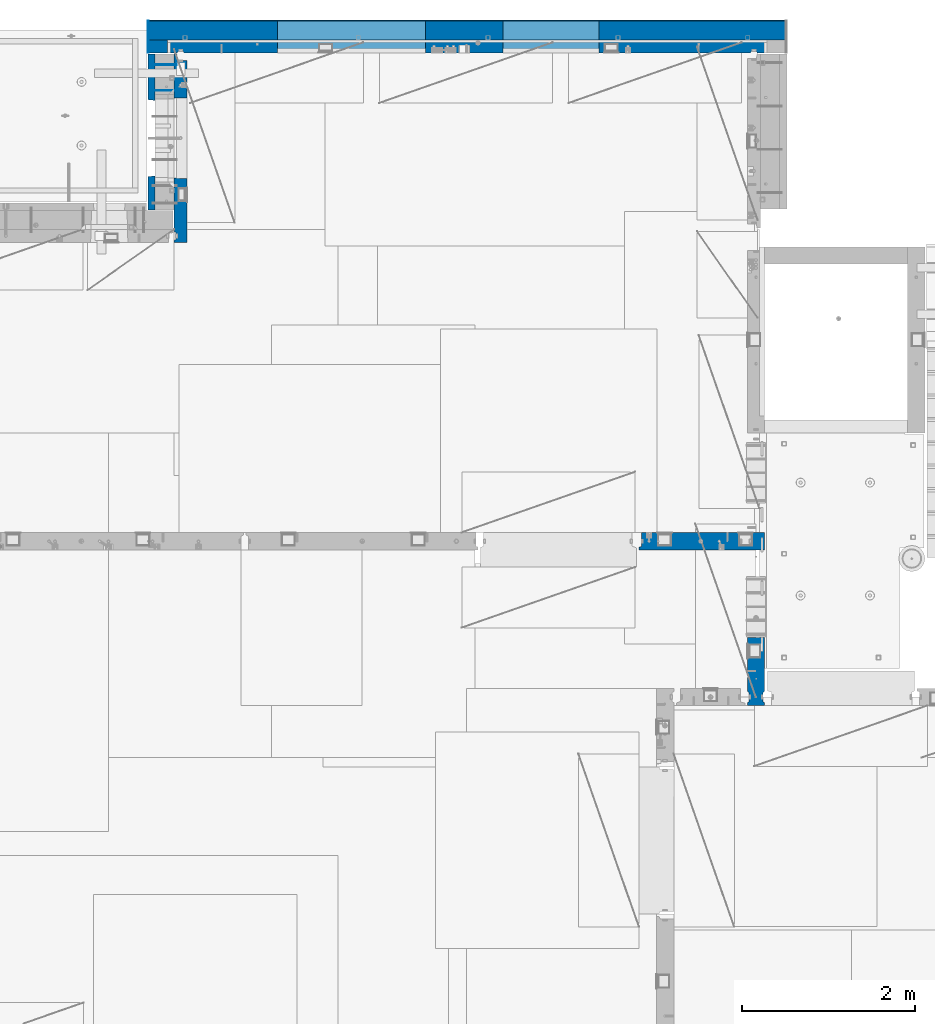
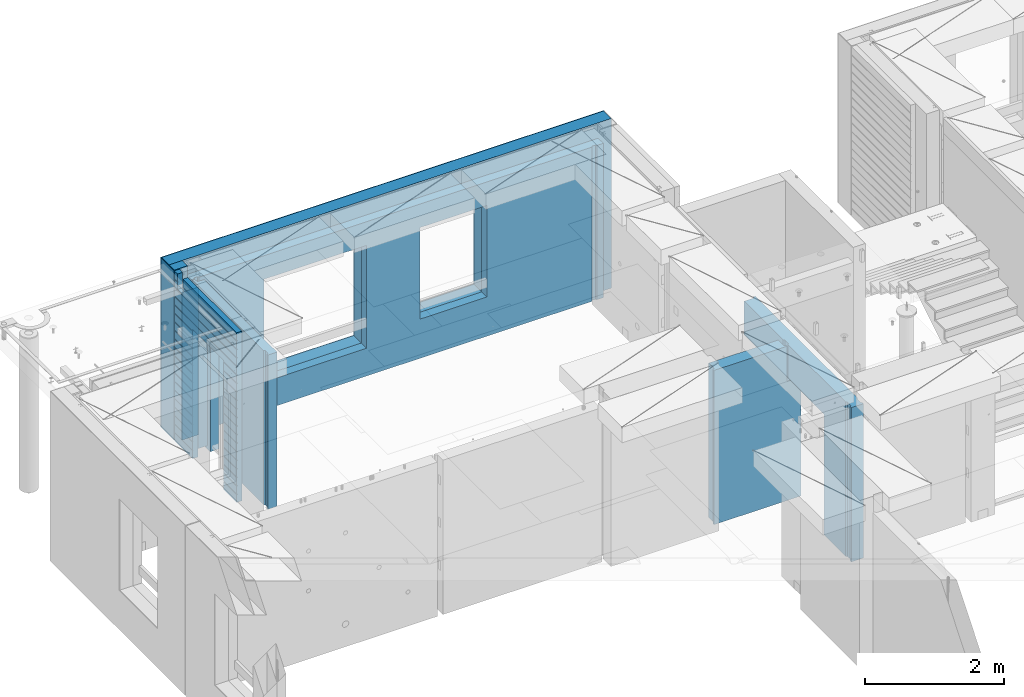
# One storey, part 226 of 334: 11 walls, 4 elements without a shape of their own.
"""IFC2X3 building model written with IfcOpenShell, lengths in millimetres."""

from ifc_helpers import new_model, si_unit, frame, origin_with_axes, place, context, subcontext, project, spatial, faceted_brep, material, type_object, element, aggregate, save


model = new_model("IFC2X3")

# Units and contexts
model_context = context("Model", 3, precision=1e-05, world=origin_with_axes())
body_context = subcontext(model_context, "Body", "Model", "MODEL_VIEW")
ifc_project = project(units=[si_unit("LENGTHUNIT", "METRE", prefix="MILLI"), si_unit("AREAUNIT", "SQUARE_METRE"), si_unit("VOLUMEUNIT", "CUBIC_METRE"), si_unit("MASSUNIT", "GRAM", prefix="KILO"), si_unit("TIMEUNIT", "SECOND"), si_unit("PLANEANGLEUNIT", "RADIAN"), si_unit("SOLIDANGLEUNIT", "STERADIAN"), si_unit("THERMODYNAMICTEMPERATUREUNIT", "DEGREE_CELSIUS"), si_unit("LUMINOUSINTENSITYUNIT", "LUMEN")], contexts=[model_context])

# Site, building, storey
site_placement = place(None, origin_with_axes())
site = spatial("IfcSite", under=ifc_project, at=site_placement, CompositionType="ELEMENT")
building_placement = place(site_placement, origin_with_axes())
building = spatial("IfcBuilding", under=site, at=building_placement, CompositionType="ELEMENT")
storey_placement = place(building_placement, origin_with_axes())
storey = spatial("IfcBuildingStorey", under=building, at=storey_placement, Name="3", CompositionType="ELEMENT", Elevation=0.0)

# Assembly, walls
assembly_1_placement = place(storey_placement, origin_with_axes())
assembly_1 = element("IfcElementAssembly", 1, at=assembly_1_placement, inside=storey, AssemblyPlace="NOTDEFINED", PredefinedType="REINFORCEMENT_UNIT")
ifc_material_1 = material(Name="Undefined")
wall_type_1 = type_object("IfcWallType", PredefinedType="NOTDEFINED")
wall_1_placement = place(assembly_1_placement, frame((11020.0, 22485.0002441406, 89115.0), z_axis=(0.0, 0.0, 1.0), x_axis=(-1.0, 3.00000001838171e-08, 0.0)))
wall_1 = element("IfcWall", 2, at=wall_1_placement, type_object=wall_type_1, material=ifc_material_1, Name="(PD)", context=body_context, shape_type="Brep", body=[
    faceted_brep([(0.0, 5.0, -1300.0), (0.0, 5.0, 1300.0), (280.0, 5.0, 1300.0), (280.0, 5.0, -1300.0), (0.0, -5.0, 1300.0), (280.0, -5.0, 1300.0), (0.0, -5.0, -1300.0), (280.0, -5.0, -1300.0)], [[[0, 1, 2, 3]], [[1, 4, 5, 2]], [[4, 6, 7, 5]], [[6, 0, 3, 7]], [[5, 7, 3, 2]], [[6, 4, 1, 0]]]),
])
wall_2_placement = place(assembly_1_placement, frame((11020.0, 22185.0002441406, 89115.0), z_axis=(0.0, 0.0, 1.0), x_axis=(-1.0, 3.00000001838171e-08, 0.0)))
wall_2 = element("IfcWall", 3, at=wall_2_placement, type_object=wall_type_1, material=ifc_material_1, Name="(PD)", context=body_context, shape_type="Brep", body=[
    faceted_brep([(0.0, 5.0, -1300.0), (0.0, 5.0, 1300.0), (280.0, 5.0, 1300.0), (280.0, 5.0, -1300.0), (0.0, -5.0, 1300.0), (280.0, -5.0, 1300.0), (0.0, -5.0, -1300.0), (280.0, -5.0, -1300.0)], [[[0, 1, 2, 3]], [[1, 4, 5, 2]], [[4, 6, 7, 5]], [[6, 0, 3, 7]], [[5, 7, 3, 2]], [[6, 4, 1, 0]]]),
])

# Assembly, wall
assembly_2_placement = place(storey_placement, origin_with_axes())
assembly_2 = element("IfcElementAssembly", 4, at=assembly_2_placement, inside=storey, AssemblyPlace="NOTDEFINED", PredefinedType="REINFORCEMENT_UNIT")
ifc_material_2 = material(Name="CONCRETE/C25/30")
wall_type_2 = type_object("IfcWallType", PredefinedType="NOTDEFINED")
wall_3_placement = place(assembly_2_placement, frame((16359.9991042544, 16980.0, 89112.5), z_axis=(0.0, 0.0, 1.0), x_axis=(1.0, 0.0, 0.0)))
wall_3 = element("IfcWall", 5, at=wall_3_placement, type_object=wall_type_2, material=ifc_material_2, context=body_context, shape_type="Brep", body=[
    faceted_brep([(1185.00089736511, 100.0, 1357.5), (1185.00089574558, -57.0, 1357.5), (1185.00089574558, -57.0, 742.5), (1185.00089736511, 99.9999999278843, 742.5), (1220.00089574558, -70.2708332915754, 1357.5), (1220.00089574558, -70.270833291579, 742.5), (1220.00089574558, 100.000001967095, 742.5), (0.0, -100.0, -1357.5), (0.0, -100.0, 1357.5), (0.0, -70.0000178764712, 1357.5), (0.0, -70.0000178764712, -1357.5), (30.0000412533973, -57.0, 1357.5), (30.0000412533973, -57.0, -1357.5), (30.0000000000009, 100.0, 1357.5), (30.0, 100.0, -1357.5), (1450.0, 100.0, -1357.5), (1450.0, -100.0, -1357.5), (1450.00089574558, 100.0, 742.5), (1450.0, -100.0, 742.5), (1220.00089574558, -100.0, 1357.5), (1220.00089574558, -100.0, 742.5), (1225.00089532057, 100.0, 742.5)], [[[0, 1, 2, 3]], [[4, 5, 2, 1]], [[6, 3, 2, 5]], [[7, 8, 9, 10]], [[11, 12, 10, 9]], [[13, 14, 12, 11]], [[15, 16, 7, 10, 12, 14]], [[16, 15, 17, 18]], [[19, 8, 7, 16, 18, 20]], [[17, 21, 6, 5, 20, 18]], [[19, 20, 5, 4]], [[0, 13, 11, 9, 8, 19, 4, 1]], [[21, 17, 15, 14, 13, 0, 3, 6]]]),
])
aggregate(assembly_2, [wall_3])

assembly_3_placement = place(storey_placement, origin_with_axes())
assembly_3 = element("IfcElementAssembly", 6, at=assembly_3_placement, inside=storey, AssemblyPlace="NOTDEFINED", PredefinedType="REINFORCEMENT_UNIT")
wall_4_placement = place(assembly_3_placement, frame((17710.0, 15080.0, 89112.5), z_axis=(0.0, 0.0, 1.0), x_axis=(0.0, 1.0, 0.0)))
wall_4 = element("IfcWall", 7, at=wall_4_placement, type_object=wall_type_2, material=ifc_material_2, context=body_context, shape_type="Brep", body=[
    faceted_brep([(3089.99926636568, -57.0, 1357.5), (3089.99926636568, -57.0, 762.5), (3089.99926620436, 100.0, 762.5), (3089.99926636568, 100.0, 1357.5), (3119.99926636568, -70.0, 1357.5), (3119.99926636568, -69.9999995451544, 762.5), (1965.00000368528, 100.0, 1357.5), (1965.00000368528, 99.9999997455598, 762.5), (1951.9999991369, 80.0000000823711, 762.5), (1951.9999991369, 80.0000000823711, 1357.5), (1848.00000041054, 79.9999993903439, 762.5), (1848.00000041054, 79.9999993903439, 1357.5), (1835.0, 100.0, 762.5), (1835.0, 100.0, 1357.5), (790.003238525391, -100.0, -1357.5), (790.003238525391, 100.0, -1357.5), (790.003238525391, 100.0, 762.5), (790.003238525391, -100.0, 762.5), (164.999999999998, 100.0, -1357.5), (164.999999999996, 100.0, 1357.5), (47.9997742438973, -79.9991481948964, 1357.5), (47.9997742438991, -79.9991481948928, -1357.5), (152.000000457021, -79.9991466091124, -1357.5), (152.000000457019, -79.9991466091124, 1357.5), (34.9997701872417, -100.0, 1357.5), (34.9997701872435, -100.0, -1357.5), (0.0, -100.0, 1357.5), (0.0, -100.0, -1357.5), (0.0, 100.0, 1357.5), (0.0, 100.0, -1357.5), (35.0, 100.0, 1357.5), (35.0, 100.0, -1357.5), (48.0, 80.0, 1357.5), (48.0, 80.0, -1357.5), (152.0, 80.0, 1357.5), (152.0, 80.0, -1357.5), (165.0, -100.0, -1357.5), (164.999999999998, -99.9991455078125, 1357.5), (3119.99926636568, -100.0, 762.5), (3119.99926636568, -100.0, 1357.5)], [[[0, 1, 2, 3]], [[4, 5, 1, 0]], [[6, 7, 8, 9]], [[9, 8, 10, 11]], [[11, 10, 12, 13]], [[14, 15, 16, 17]], [[13, 12, 16, 15, 18, 19]], [[20, 21, 22, 23]], [[24, 25, 21, 20]], [[26, 27, 25, 24]], [[27, 26, 28, 29]], [[29, 28, 30, 31]], [[32, 33, 31, 30]], [[34, 35, 33, 32]], [[19, 18, 35, 34]], [[15, 14, 36, 22, 21, 25, 27, 29, 31, 33, 35, 18]], [[37, 23, 22, 36]], [[14, 17, 38, 39, 37, 36]], [[13, 19, 34, 32, 30, 28, 26, 24, 20, 23, 37, 39, 4, 0, 3, 6, 9, 11]], [[7, 6, 3, 2]], [[38, 17, 16, 12, 10, 8, 7, 2, 1, 5]], [[39, 38, 5, 4]]]),
])
aggregate(assembly_3, [wall_4])

# Assembly, walls
assembly_4_placement = place(storey_placement, origin_with_axes())
assembly_4 = element("IfcElementAssembly", 8, at=assembly_4_placement, inside=storey, AssemblyPlace="NOTDEFINED", PredefinedType="REINFORCEMENT_UNIT")
ifc_material_3 = material()
wall_type_3 = type_object("IfcWallType", PredefinedType="NOTDEFINED")
wall_5_placement = place(assembly_4_placement, frame((10805.0, 22620.0, 89247.5), z_axis=(0.0, 0.0, 1.0), x_axis=(0.0, 1.0, 0.0)))
wall_5 = element("IfcWall", 9, at=wall_5_placement, type_object=wall_type_3, material=ifc_material_3, context=body_context, shape_type="Brep", body=[
    faceted_brep([(0.0, 110.0, -1492.5), (0.0, 110.0, 1492.5), (150.0, 110.0, 1492.5), (150.0, 110.0, -1492.5), (0.0, -110.0, 1492.5), (150.0, -110.0, 1492.5), (0.0, -110.0, -1492.5), (150.0, -110.0, -1492.5)], [[[0, 1, 2, 3]], [[1, 4, 5, 2]], [[4, 6, 7, 5]], [[6, 0, 3, 7]], [[5, 7, 3, 2]], [[6, 4, 1, 0]]]),
])
wall_6_placement = place(assembly_4_placement, frame((10915.0, 22880.0, 89247.5), z_axis=(0.0, 0.0, 1.0), x_axis=(1.0, 0.0, 0.0)))
wall_6 = element("IfcWall", 10, at=wall_6_placement, type_object=wall_type_3, material=ifc_material_3, context=body_context, shape_type="Brep", body=[
    faceted_brep([(3869.99997871358, 110.0, 807.5), (3869.99997871358, -110.0, 807.5), (3869.99997871358, -110.0, -802.5), (3869.99997871358, 110.0, -802.5), (4979.99997871358, -110.0, -802.5), (4979.99997871358, 110.0, -802.5), (4979.99997871358, -110.0, 807.5), (4979.99997871358, 110.0, 807.5), (-220.0, 110.0, 1492.5), (-220.0, -110.0, 1492.5), (7140.0, -110.0, 1492.5), (7140.0, 110.0, 1492.5), (-220.0, -110.0, -1492.5), (-220.0, 110.0, -1492.5), (7140.0, 110.0, -1492.5), (7140.0, -110.0, -1492.5), (1270.00055091817, 110.0, -1002.5), (2980.00055091817, 110.0, -1002.5), (2980.00055091817, 110.0, 807.5), (1270.00055091817, 110.0, 807.5), (1270.00055091817, -110.0, -1002.5), (2980.00055091817, -110.0, -1002.5), (1270.00055091817, -110.0, 807.5), (2980.00055091817, -110.0, 807.5)], [[[0, 1, 2, 3]], [[3, 2, 4, 5]], [[5, 4, 6, 7]], [[7, 6, 1, 0]], [[8, 9, 10, 11]], [[12, 9, 8, 13]], [[12, 13, 14, 15]], [[10, 15, 14, 11]], [[13, 8, 11, 14], [3, 5, 7, 0], [16, 17, 18, 19]], [[16, 20, 21, 17]], [[19, 22, 20, 16]], [[18, 23, 22, 19]], [[17, 21, 23, 18]], [[9, 12, 15, 10], [2, 1, 6, 4], [20, 22, 23, 21]]]),
])

# Wall
ifc_material_4 = material(Name="CONCRETE/C30/37")
wall_type_4 = type_object("IfcWallType", PredefinedType="NOTDEFINED")
wall_7_placement = place(assembly_1_placement, frame((10727.5, 20805.0, 89247.5), z_axis=(0.0, 0.0, 1.0), x_axis=(0.0, 1.0, 0.0)))
wall_7 = element("IfcWall", 11, at=wall_7_placement, type_object=wall_type_4, material=ifc_material_4, context=body_context, shape_type="Brep", body=[
    faceted_brep([(1800.0, -42.5, 1492.5), (1800.0, 42.5, 1492.5), (1705.0, 42.5, 1492.5), (1705.0, -42.5, 1492.5), (0.0, 42.5, -1492.5), (0.0, 42.5, -1357.00000005524), (384.998212827581, 42.5, -1357.00000005524), (384.998212827581, 42.5, -1492.5), (0.0, 32.4999992507037, -1355.00000000074), (386.174879582417, 32.4999992506928, -1355.0000000008), (0.0, 32.4999991127006, -1344.99999959956), (386.174879598653, 32.4999991126915, -1344.99999959957), (0.0, 42.5, -1343.00000011075), (384.998212827581, 42.5, -1343.00000011075), (0.0, 42.5, -1207.00000005524), (384.998212827581, 42.5, -1207.00000005524), (0.0, 32.4999992507037, -1205.00000000074), (386.174879582417, 32.4999992506928, -1205.0000000008), (0.0, 32.4999991127006, -1194.99999959956), (386.174879598653, 32.4999991126915, -1194.99999959957), (0.0, 42.5, -1193.00000011075), (384.998212827581, 42.5, -1193.00000011075), (0.0, 42.5, -1057.00000005524), (384.998212827581, 42.5, -1057.00000005524), (0.0, 32.4999992507037, -1055.00000000074), (386.174879582417, 32.4999992506928, -1055.0000000008), (0.0, 32.4999991127006, -1044.99999959956), (386.174879598653, 32.4999991126915, -1044.99999959957), (0.0, 42.5, -1043.00000011075), (384.998212827581, 42.5, -1043.00000011075), (0.0, 42.5, -907.000000055239), (384.998212827581, 42.5, -907.000000055239), (0.0, 32.4999992507037, -905.000000000742), (386.174879582417, 32.4999992506928, -905.0000000008), (0.0, 32.4999991127006, -894.99999959956), (386.174879598653, 32.4999991126915, -894.999999599575), (0.0, 42.5, -893.000000110755), (384.998212827581, 42.5, -893.000000110755), (0.0, 42.5, -757.000000055239), (384.998212827581, 42.5, -757.000000055239), (0.0, 32.4999992507037, -755.000000000742), (386.174879582417, 32.4999992506928, -755.0000000008), (0.0, 32.4999991127006, -744.99999959956), (386.174879598653, 32.4999991126915, -744.999999599575), (0.0, 42.5, -743.000000110755), (384.998212827581, 42.5, -743.000000110755), (0.0, 42.5, -607.000000055239), (384.998212827581, 42.5, -607.000000055239), (3.63797880709171e-12, 32.4999992507037, -605.000000000742), (386.174879582417, 32.4999992506928, -605.0000000008), (3.63797880709171e-12, 32.4999991127006, -594.99999959956), (386.174879598653, 32.4999991126915, -594.999999599575), (0.0, 42.5, -593.000000110755), (384.998212827581, 42.5, -593.000000110755), (0.0, 42.5, -457.000000055239), (384.998212827581, 42.5, -457.000000055239), (0.0, 32.4999992507037, -455.000000000742), (386.174879582417, 32.4999992506928, -455.0000000008), (0.0, 32.4999991127006, -444.99999959956), (386.174879598653, 32.4999991126915, -444.999999599575), (0.0, 42.5, -443.000000110755), (384.998212827581, 42.5, -443.000000110755), (0.0, 42.5, -307.000000055239), (384.998212827581, 42.5, -307.000000055239), (0.0, 32.4999992507037, -305.000000000742), (386.174879582417, 32.4999992506928, -305.0000000008), (0.0, 32.4999991127006, -294.99999959956), (386.174879598653, 32.4999991126915, -294.999999599575), (0.0, 42.5, -293.000000110755), (384.998212827581, 42.5, -293.000000110755), (0.0, 42.5, -157.000000055239), (384.998212827581, 42.5, -157.000000055239), (3.63797880709171e-12, 32.4999992507037, -155.000000000742), (386.174879582417, 32.4999992506928, -155.0000000008), (3.63797880709171e-12, 32.4999991127006, -144.99999959956), (386.174879598653, 32.4999991126915, -144.999999599575), (0.0, 42.5, -143.000000110755), (384.998212827581, 42.5, -143.000000110755), (0.0, 42.5, -7.00000005523907), (384.998212827581, 42.5, -7.00000005523907), (0.0, 32.4999992507037, -5.00000000074215), (386.174879582417, 32.4999992506928, -5.00000000080036), (0.0, 32.4999991127006, 5.0000004004396), (386.174879598653, 32.4999991126915, 5.00000040042505), (0.0, 42.5, 6.99999988924537), (384.998212827581, 42.5, 6.99999988924537), (0.0, 42.5, 142.999999944761), (384.998212827581, 42.5, 142.999999944761), (-3.63797880709171e-12, 32.4999992507037, 144.999999999258), (386.174879582417, 32.4999992506928, 144.9999999992), (-3.63797880709171e-12, 32.4999991127006, 155.00000040044), (386.174879598653, 32.4999991126915, 155.000000400425), (0.0, 42.5, 156.999999889245), (384.998212827581, 42.5, 156.999999889245), (0.0, 42.5, 292.999999944761), (384.998212827581, 42.5, 292.999999944761), (-3.63797880709171e-12, 32.4999992507037, 294.999999999258), (386.174879582417, 32.4999992506928, 294.9999999992), (-3.63797880709171e-12, 32.4999991127006, 305.00000040044), (386.174879598653, 32.4999991126915, 305.000000400425), (0.0, 42.5, 306.999999889245), (384.998212827581, 42.5, 306.999999889245), (0.0, 42.5, 442.999999944761), (384.998212827581, 42.5, 442.999999944761), (0.0, 32.4999992507037, 444.999999999258), (386.174879582417, 32.4999992506928, 444.9999999992), (0.0, 32.4999991127006, 455.00000040044), (386.174879598653, 32.4999991126915, 455.000000400425), (0.0, 42.5, 456.999999889245), (384.998212827581, 42.5, 456.999999889245), (0.0, 42.5, 592.999999944761), (384.998212827581, 42.5, 592.999999944761), (3.63797880709171e-12, 32.4999992507037, 594.999999999258), (386.174879582417, 32.4999992506928, 594.9999999992), (3.63797880709171e-12, 32.4999991127006, 605.00000040044), (386.174879598653, 32.4999991126915, 605.000000400425), (0.0, 42.5, 606.999999889245), (384.998212827581, 42.5, 606.999999889245), (0.0, 42.5, 742.999999944761), (384.998212827581, 42.5, 742.999999944761), (0.0, 32.4999992507037, 744.999999999258), (386.174879582417, 32.4999992506928, 744.9999999992), (0.0, 32.4999991127006, 755.00000040044), (386.174879598653, 32.4999991126915, 755.000000400425), (0.0, 42.5, 756.999999889245), (384.998212827581, 42.5, 756.999999889245), (0.0, 42.5, 1206.99999988925), (1800.0, 42.5, 1206.99999988925), (1800.0, 32.4999991126897, 1205.00000040043), (0.0, 32.4999991127006, 1205.00000040044), (1800.0, 32.4999992507001, 1194.99999999923), (0.0, 32.4999992507037, 1194.99999999926), (0.0, 42.5, 1192.99999994476), (1800.0, 42.5, 1192.99999994476), (1800.0, 42.5, 1056.99999988925), (0.0, 42.5, 1056.99999988925), (1800.0, 32.4999991126897, 1055.00000040043), (0.0, 32.4999991127006, 1055.00000040044), (1800.0, 32.4999992507001, 1044.99999999923), (0.0, 32.4999992507037, 1044.99999999926), (0.0, 42.5, 1042.99999994476), (1800.0, 42.5, 1042.99999994476), (1800.0, 42.5, 906.999999889245), (0.0, 42.5, 906.999999889245), (1800.0, 32.4999991126897, 905.000000400425), (0.0, 32.4999991127006, 905.00000040044), (1800.0, 32.4999992507001, 894.999999999229), (0.0, 32.4999992507037, 894.999999999258), (0.0, 42.5, 892.999999944761), (1800.0, 42.5, 892.999999944761), (1800.0, 42.5, -1357.00000005524), (1800.0, 42.5, -1492.5), (1274.99821282758, 42.5, -1492.5), (1274.99821282758, 42.5, -1357.00000005524), (1800.0, 32.4999992507001, -1355.00000000077), (1273.82154607274, 32.4999992506928, -1355.0000000008), (1800.0, 32.4999991126897, -1344.99999959957), (1273.82154605651, 32.4999991126915, -1344.99999959957), (1800.0, 42.5, -1343.00000011075), (1274.99821282758, 42.5, -1343.00000011075), (1800.0, 42.5, -1207.00000005524), (1274.99821282758, 42.5, -1207.00000005524), (1800.0, 32.4999992507001, -1205.00000000077), (1273.82154607274, 32.4999992506928, -1205.0000000008), (1800.0, 32.4999991126897, -1194.99999959957), (1273.82154605651, 32.4999991126915, -1194.99999959957), (1800.0, 42.5, -1193.00000011075), (1274.99821282758, 42.5, -1193.00000011075), (1800.0, 42.5, -1057.00000005524), (1274.99821282758, 42.5, -1057.00000005524), (1800.0, 32.4999992507001, -1055.00000000077), (1273.82154607274, 32.4999992506928, -1055.0000000008), (1800.0, 32.4999991126897, -1044.99999959957), (1273.82154605651, 32.4999991126915, -1044.99999959957), (1800.0, 42.5, -1043.00000011075), (1274.99821282758, 42.5, -1043.00000011075), (1800.0, 42.5, -907.000000055239), (1274.99821282758, 42.5, -907.000000055239), (1800.0, 32.4999992507001, -905.000000000771), (1273.82154607274, 32.4999992506928, -905.0000000008), (1800.0, 32.4999991126897, -894.999999599575), (1273.82154605651, 32.4999991126915, -894.999999599575), (1800.0, 42.5, -893.000000110755), (1274.99821282758, 42.5, -893.000000110755), (1800.0, 42.5, -757.000000055239), (1274.99821282758, 42.5, -757.000000055239), (1800.0, 32.4999992507001, -755.000000000771), (1273.82154607274, 32.4999992506928, -755.0000000008), (1800.0, 32.4999991126897, -744.999999599575), (1273.82154605651, 32.4999991126915, -744.999999599575), (1800.0, 42.5, -743.000000110755), (1274.99821282758, 42.5, -743.000000110755), (1800.0, 42.5, -607.000000055239), (1274.99821282758, 42.5, -607.000000055239), (1800.0, 32.4999992507001, -605.000000000771), (1273.82154607274, 32.4999992506928, -605.0000000008), (1800.0, 32.4999991126897, -594.999999599575), (1273.82154605651, 32.4999991126915, -594.999999599575), (1800.0, 42.5, -593.000000110755), (1274.99821282758, 42.5, -593.000000110755), (1800.0, 42.5, -457.000000055239), (1274.99821282758, 42.5, -457.000000055239), (1800.0, 32.4999992507001, -455.000000000771), (1273.82154607274, 32.4999992506928, -455.0000000008), (1800.0, 32.4999991126897, -444.999999599575), (1273.82154605651, 32.4999991126915, -444.999999599575), (1800.0, 42.5, -443.000000110755), (1274.99821282758, 42.5, -443.000000110755), (1800.0, 42.5, -307.000000055239), (1274.99821282758, 42.5, -307.000000055239), (1800.0, 32.4999992507001, -305.000000000771), (1273.82154607274, 32.4999992506928, -305.0000000008), (1800.0, 32.4999991126897, -294.999999599575), (1273.82154605651, 32.4999991126915, -294.999999599575), (1800.0, 42.5, -293.000000110755), (1274.99821282758, 42.5, -293.000000110755), (1800.0, 42.5, -157.000000055239), (1274.99821282758, 42.5, -157.000000055239), (1800.0, 32.4999992507001, -155.000000000771), (1273.82154607274, 32.4999992506928, -155.0000000008), (1800.0, 32.4999991126897, -144.999999599575), (1273.82154605651, 32.4999991126915, -144.999999599575), (1800.0, 42.5, -143.000000110755), (1274.99821282758, 42.5, -143.000000110755), (1800.0, 42.5, -7.00000005523907), (1274.99821282758, 42.5, -7.00000005523907), (1800.0, 32.4999992507001, -5.00000000077125), (1273.82154607274, 32.4999992506928, -5.00000000080036), (1800.0, 32.4999991126897, 5.00000040042505), (1273.82154605651, 32.4999991126915, 5.00000040042505), (1800.0, 42.5, 6.99999988924537), (1274.99821282758, 42.5, 6.99999988924537), (1800.0, 42.5, 142.999999944761), (1274.99821282758, 42.5, 142.999999944761), (1800.0, 32.4999992507001, 144.999999999229), (1273.82154607274, 32.4999992506928, 144.9999999992), (1800.0, 32.4999991126897, 155.000000400425), (1273.82154605651, 32.4999991126915, 155.000000400425), (1800.0, 42.5, 156.999999889245), (1274.99821282758, 42.5, 156.999999889245), (1800.0, 42.5, 292.999999944761), (1274.99821282758, 42.5, 292.999999944761), (1800.0, 32.4999992507001, 294.999999999229), (1273.82154607274, 32.4999992506928, 294.9999999992), (1800.0, 32.4999991126897, 305.000000400425), (1273.82154605651, 32.4999991126915, 305.000000400425), (1800.0, 42.5, 306.999999889245), (1274.99821282758, 42.5, 306.999999889245), (1800.0, 42.5, 442.999999944761), (1274.99821282758, 42.5, 442.999999944761), (1800.0, 32.4999992507001, 444.999999999229), (1273.82154607274, 32.4999992506928, 444.9999999992), (1800.0, 32.4999991126897, 455.000000400425), (1273.82154605651, 32.4999991126915, 455.000000400425), (1800.0, 42.5, 456.999999889245), (1274.99821282758, 42.5, 456.999999889245), (1800.0, 42.5, 592.999999944761), (1274.99821282758, 42.5, 592.999999944761), (1800.0, 32.4999992507001, 594.999999999229), (1273.82154607274, 32.4999992506928, 594.9999999992), (1800.0, 32.4999991126897, 605.000000400425), (1273.82154605651, 32.4999991126915, 605.000000400425), (1800.0, 42.5, 606.999999889245), (1274.99821282758, 42.5, 606.999999889245), (1800.0, 42.5, 742.999999944761), (1274.99821282758, 42.5, 742.999999944761), (1800.0, 32.4999992507001, 744.999999999229), (1273.82154607274, 32.4999992506928, 744.9999999992), (1800.0, 32.4999991126897, 755.000000400425), (1273.82154605651, 32.4999991126915, 755.000000400425), (1800.0, 42.5, 756.999999889245), (1274.99821282758, 42.5, 756.999999889245), (395.000271651108, 42.5, 782.5), (384.998212827581, 42.5, 782.5), (1274.99821282758, 42.5, 782.5), (1265.00027165111, 42.5, 782.5), (394.999879494248, -42.5, 787.502857142856), (1264.99654616091, -42.5, 787.502857142856), (394.999879494248, -42.5, 782.5), (394.999879494248, -42.5, -1492.5), (0.0, -42.5, -1492.5), (-3.63797880709171e-12, 32.4999992507037, 1344.99999999926), (0.0, 42.5, 1342.99999994476), (0.0, -42.5, 1492.5), (0.0, 42.5, 1492.5), (0.0, 42.5, 1356.99999988925), (-3.63797880709171e-12, 32.4999991127006, 1355.00000040044), (1555.0, 42.5, 1356.99999988925), (1555.0, 32.4999991126915, 1355.00000040043), (1555.0, 32.4999992506928, 1344.9999999992), (1555.0, 42.5, 1342.99999994476), (1800.0, 42.5, 1342.99999994476), (1555.0, 42.5, 1222.5), (1705.0, 42.5, 1222.5), (1705.0, 42.5, 1343.0), (1800.0, 32.4999992507001, 1344.99999999923), (1705.0, 32.5, 1345.0), (1800.0, 32.4999991126897, 1355.00000040043), (1705.0, 32.5, 1355.0), (1800.0, 42.5, 1356.99999988925), (1705.0, 42.5, 1357.0), (1800.0, -42.5, -1492.5), (1264.99654616091, -42.5, -1492.5), (1264.99654616091, -42.5, 782.5), (1705.0, -42.5, 1222.5), (1555.0, -42.5, 1222.5), (1555.0, -42.5, 1492.5), (1555.0, 42.5, 1492.5)], [[[0, 1, 2, 3]], [[4, 5, 6, 7]], [[5, 8, 9, 6]], [[8, 10, 11, 9]], [[10, 12, 13, 11]], [[12, 14, 15, 13]], [[14, 16, 17, 15]], [[16, 18, 19, 17]], [[18, 20, 21, 19]], [[20, 22, 23, 21]], [[22, 24, 25, 23]], [[24, 26, 27, 25]], [[26, 28, 29, 27]], [[28, 30, 31, 29]], [[30, 32, 33, 31]], [[32, 34, 35, 33]], [[34, 36, 37, 35]], [[36, 38, 39, 37]], [[38, 40, 41, 39]], [[40, 42, 43, 41]], [[42, 44, 45, 43]], [[44, 46, 47, 45]], [[46, 48, 49, 47]], [[48, 50, 51, 49]], [[50, 52, 53, 51]], [[52, 54, 55, 53]], [[54, 56, 57, 55]], [[56, 58, 59, 57]], [[58, 60, 61, 59]], [[60, 62, 63, 61]], [[62, 64, 65, 63]], [[64, 66, 67, 65]], [[66, 68, 69, 67]], [[68, 70, 71, 69]], [[70, 72, 73, 71]], [[72, 74, 75, 73]], [[74, 76, 77, 75]], [[76, 78, 79, 77]], [[78, 80, 81, 79]], [[80, 82, 83, 81]], [[82, 84, 85, 83]], [[84, 86, 87, 85]], [[86, 88, 89, 87]], [[88, 90, 91, 89]], [[90, 92, 93, 91]], [[92, 94, 95, 93]], [[94, 96, 97, 95]], [[96, 98, 99, 97]], [[98, 100, 101, 99]], [[100, 102, 103, 101]], [[102, 104, 105, 103]], [[104, 106, 107, 105]], [[106, 108, 109, 107]], [[108, 110, 111, 109]], [[110, 112, 113, 111]], [[112, 114, 115, 113]], [[114, 116, 117, 115]], [[116, 118, 119, 117]], [[118, 120, 121, 119]], [[120, 122, 123, 121]], [[122, 124, 125, 123]], [[126, 127, 128, 129]], [[129, 128, 130, 131]], [[132, 131, 130, 133]], [[134, 135, 132, 133]], [[135, 134, 136, 137]], [[137, 136, 138, 139]], [[140, 139, 138, 141]], [[142, 143, 140, 141]], [[143, 142, 144, 145]], [[145, 144, 146, 147]], [[148, 147, 146, 149]], [[150, 151, 152, 153]], [[154, 150, 153, 155]], [[156, 154, 155, 157]], [[158, 156, 157, 159]], [[160, 158, 159, 161]], [[162, 160, 161, 163]], [[164, 162, 163, 165]], [[166, 164, 165, 167]], [[168, 166, 167, 169]], [[170, 168, 169, 171]], [[172, 170, 171, 173]], [[174, 172, 173, 175]], [[176, 174, 175, 177]], [[178, 176, 177, 179]], [[180, 178, 179, 181]], [[182, 180, 181, 183]], [[184, 182, 183, 185]], [[186, 184, 185, 187]], [[188, 186, 187, 189]], [[190, 188, 189, 191]], [[192, 190, 191, 193]], [[194, 192, 193, 195]], [[196, 194, 195, 197]], [[198, 196, 197, 199]], [[200, 198, 199, 201]], [[202, 200, 201, 203]], [[204, 202, 203, 205]], [[206, 204, 205, 207]], [[208, 206, 207, 209]], [[210, 208, 209, 211]], [[212, 210, 211, 213]], [[214, 212, 213, 215]], [[216, 214, 215, 217]], [[218, 216, 217, 219]], [[220, 218, 219, 221]], [[222, 220, 221, 223]], [[224, 222, 223, 225]], [[226, 224, 225, 227]], [[228, 226, 227, 229]], [[230, 228, 229, 231]], [[232, 230, 231, 233]], [[234, 232, 233, 235]], [[236, 234, 235, 237]], [[238, 236, 237, 239]], [[240, 238, 239, 241]], [[242, 240, 241, 243]], [[244, 242, 243, 245]], [[246, 244, 245, 247]], [[248, 246, 247, 249]], [[250, 248, 249, 251]], [[252, 250, 251, 253]], [[254, 252, 253, 255]], [[256, 254, 255, 257]], [[258, 256, 257, 259]], [[260, 258, 259, 261]], [[262, 260, 261, 263]], [[264, 262, 263, 265]], [[266, 264, 265, 267]], [[268, 266, 267, 269]], [[270, 268, 269, 271]], [[272, 273, 125, 124, 148, 149, 270, 271, 274, 275]], [[276, 273, 272, 275, 274, 277]], [[278, 279, 7, 6, 9, 11, 13, 15, 17, 19, 21, 23, 25, 27, 29, 31, 33, 35, 37, 39, 41, 43, 45, 47, 49, 51, 53, 55, 57, 59, 61, 63, 65, 67, 69, 71, 73, 75, 77, 79, 81, 83, 85, 87, 89, 91, 93, 95, 97, 99, 101, 103, 105, 107, 109, 111, 113, 115, 117, 119, 121, 123, 125, 273, 276]], [[280, 4, 7, 279]], [[281, 282, 126, 129, 131, 132, 135, 137, 139, 140, 143, 145, 147, 148, 124, 122, 120, 118, 116, 114, 112, 110, 108, 106, 104, 102, 100, 98, 96, 94, 92, 90, 88, 86, 84, 82, 80, 78, 76, 74, 72, 70, 68, 66, 64, 62, 60, 58, 56, 54, 52, 50, 48, 46, 44, 42, 40, 38, 36, 34, 32, 30, 28, 26, 24, 22, 20, 18, 16, 14, 12, 10, 8, 5, 4, 280, 283, 284, 285, 286]], [[286, 285, 287, 288]], [[281, 286, 288, 289]], [[282, 281, 289, 290]], [[291, 127, 126, 282, 290, 292, 293, 294]], [[295, 291, 294, 296]], [[297, 295, 296, 298]], [[299, 297, 298, 300]], [[1, 0, 301, 151, 150, 154, 156, 158, 160, 162, 164, 166, 168, 170, 172, 174, 176, 178, 180, 182, 184, 186, 188, 190, 192, 194, 196, 198, 200, 202, 204, 206, 208, 210, 212, 214, 216, 218, 220, 222, 224, 226, 228, 230, 232, 234, 236, 238, 240, 242, 244, 246, 248, 250, 252, 254, 256, 258, 260, 262, 264, 266, 268, 270, 149, 146, 144, 142, 141, 138, 136, 134, 133, 130, 128, 127, 291, 295, 297, 299]], [[151, 301, 302, 152]], [[303, 277, 274, 271, 269, 267, 265, 263, 261, 259, 257, 255, 253, 251, 249, 247, 245, 243, 241, 239, 237, 235, 233, 231, 229, 227, 225, 223, 221, 219, 217, 215, 213, 211, 209, 207, 205, 203, 201, 199, 197, 195, 193, 191, 189, 187, 185, 183, 181, 179, 177, 175, 173, 171, 169, 167, 165, 163, 161, 159, 157, 155, 153, 152, 302]], [[302, 301, 0, 3, 304, 305, 306, 283, 280, 279, 278, 276, 277, 303]], [[284, 283, 306, 307]], [[285, 284, 307, 287]], [[306, 305, 292, 290, 289, 288, 287, 307]], [[304, 293, 292, 305]], [[3, 2, 300, 298, 296, 294, 293, 304]], [[1, 299, 300, 2]]]),
])

wall_type_5 = type_object("IfcWallType", PredefinedType="NOTDEFINED")
wall_8_placement = place(assembly_4_placement, frame((11142.5, 22695.0, 89112.5), z_axis=(0.0, 0.0, 1.0), x_axis=(1.0, 0.0, 0.0)))
wall_8 = element("IfcWall", 12, at=wall_8_placement, type_object=wall_type_5, material=ifc_material_2, context=body_context, shape_type="Brep", body=[
    faceted_brep([(3642.49997871358, 75.0, 942.5), (3642.49997871358, -75.0000009232135, 942.5), (3642.49997871358, -75.0000002283705, -667.5), (3642.49997871358, 75.0, -667.5), (4752.49997871358, -75.0000000404216, -667.5), (4752.49997871358, 75.0, -667.5), (4752.49997871358, -75.0000007352646, 942.5), (4752.49997871358, 75.0, 942.5), (6692.5, -75.0, -1357.5), (6692.5, -75.0, 1357.5), (6582.50000278437, -75.0000022790045, 1357.5), (6582.50000278437, -75.0, -1357.5), (-227.5, -75.0, -1357.5), (-227.5, -75.0, 1357.5), (-227.5, 75.0, 1357.5), (-227.5, 75.0, -1357.5), (-117.5, -75.0, -1357.5), (-117.5, -75.0, 1357.5), (-104.499999589396, -54.9999993903875, -1357.5), (-104.499999589396, -54.9999993903875, 1357.5), (-50.4999996848892, -54.9999994175341, -1357.5), (-50.4999996848892, -54.9999994175341, 1357.5), (-37.4999972154728, -75.0000022791319, 1357.5), (-37.4999972154728, -75.0, -1357.5), (6692.5, 75.0, 1357.5), (6502.49999792087, -75.0000000643449, 1357.5), (6515.49999996855, -54.9999999109496, 1357.5), (6569.49999987308, -54.999998745101, 1357.5), (6502.49999792087, -75.0, -1357.5), (6515.49999996855, -54.9999999109496, -1357.5), (6569.49999987308, -54.999998745101, -1357.5), (6692.5, 75.0, -1357.5), (1042.50055091817, 75.0, -867.5), (2752.50055091817, 75.0, -867.5), (2752.50055091817, 75.0, 942.5), (1042.50055091817, 75.0, 942.5), (1042.50055091817, -75.0000005925758, -867.5), (2752.50055091817, -75.0000003030254, -867.5), (1042.50055091817, -75.0000013522877, 942.5), (2752.50055091817, -75.0000010627373, 942.5)], [[[0, 1, 2, 3]], [[3, 2, 4, 5]], [[5, 4, 6, 7]], [[7, 6, 1, 0]], [[8, 9, 10, 11]], [[12, 13, 14, 15]], [[13, 12, 16, 17]], [[17, 16, 18, 19]], [[19, 18, 20, 21]], [[22, 21, 20, 23]], [[9, 24, 14, 13, 17, 19, 21, 22, 25, 26, 27, 10]], [[25, 28, 29, 26]], [[26, 29, 30, 27]], [[10, 27, 30, 11]], [[29, 28, 23, 20, 18, 16, 12, 15, 31, 8, 11, 30]], [[9, 8, 31, 24]], [[15, 14, 24, 31], [3, 5, 7, 0], [32, 33, 34, 35]], [[32, 36, 37, 33]], [[35, 38, 36, 32]], [[34, 39, 38, 35]], [[33, 37, 39, 34]], [[22, 23, 28, 25], [2, 1, 6, 4], [36, 38, 39, 37]]]),
])

wall_9_placement = place(assembly_1_placement, frame((11065.0, 20430.0, 89112.5), z_axis=(0.0, 0.0, 1.0), x_axis=(0.0, 1.0, 0.0)))
wall_9 = element("IfcWall", 13, at=wall_9_placement, type_object=wall_type_5, material=ifc_material_2, context=body_context, shape_type="Brep", body=[
    faceted_brep([(124.995187227563, 75.0, 1357.5), (124.995187227563, 75.0, -1357.5), (114.995187227563, 55.0, -1357.5), (114.995187227563, 55.0, 1357.5), (-0.00481277243670775, -75.0, -1357.5), (-0.00481277243670775, -75.0, 1357.5), (-0.00481277243670775, 75.0, 1357.5), (-0.00481277243670775, 75.0, -1357.5), (24.9951872275633, 75.0, 1357.5), (24.9951872275633, 75.0, -1357.5), (34.9951872275633, 55.0, 1357.5), (34.9951872275633, 55.0, -1357.5), (47.9951869124525, 54.9999994175378, 1357.5), (47.9951869124525, 54.9999994175378, -1357.5), (101.995186816988, 54.9999993903693, 1357.5), (101.995186816988, 54.9999993903693, -1357.5), (2105.0, -75.0, 1357.5), (2105.0, 32.0, 1357.5), (2175.0, 45.0, 1357.5), (2175.0, 75.0, 1357.5), (2105.0, -75.0, -1357.5), (2105.0, 32.0, -1357.5), (2175.0, 45.0, -1357.5), (2175.0, 75.0, -1357.5), (743.846425497264, 75.0, -1357.5), (1666.15411780495, 75.0, -1357.5), (1666.15411780496, 75.0, 948.653846153844), (743.846425497261, 75.0, 948.653846153844), (740.000271651108, -75.0, -1357.5), (740.000271651108, -75.0, 952.5), (1670.00027165111, -75.0, 952.5), (1670.00027165111, -75.0, -1357.5)], [[[0, 1, 2, 3]], [[4, 5, 6, 7]], [[7, 6, 8, 9]], [[10, 11, 9, 8]], [[12, 13, 11, 10]], [[14, 15, 13, 12]], [[3, 2, 15, 14]], [[12, 10, 8, 6, 5, 16, 17, 18, 19, 0, 3, 14]], [[16, 20, 21, 17]], [[17, 21, 22, 18]], [[23, 19, 18, 22]], [[24, 1, 0, 19, 23, 25, 26, 27]], [[4, 7, 9, 11, 13, 15, 2, 1, 24, 28]], [[20, 16, 5, 4, 28, 29, 30, 31]], [[23, 22, 21, 20, 31, 25]], [[30, 26, 25, 31]], [[29, 27, 26, 30]], [[28, 24, 27, 29]]]),
])

aggregate(assembly_1, [wall_1, wall_2, wall_9, wall_7])

wall_type_6 = type_object("IfcWallType", PredefinedType="NOTDEFINED")
wall_10_placement = place(assembly_4_placement, frame((10690.0, 22620.0, 89247.5), z_axis=(0.0, 0.0, 1.0), x_axis=(0.0, 1.0, 0.0)))
wall_10 = element("IfcWall", 14, at=wall_10_placement, type_object=wall_type_6, material=ifc_material_4, context=body_context, shape_type="Brep", body=[
    faceted_brep([(0.0, 5.0, -1492.5), (0.0, 5.0, 1492.5), (370.0, 5.0, 1492.5), (370.0, 5.0, -1492.5), (0.0, -5.0, 1492.5), (370.0, -5.0, 1492.5), (0.0, -5.0, -1492.5), (370.0, -5.0, -1492.5)], [[[0, 1, 2, 3]], [[1, 4, 5, 2]], [[4, 6, 7, 5]], [[6, 0, 3, 7]], [[5, 7, 3, 2]], [[6, 4, 1, 0]]]),
])

wall_11_placement = place(assembly_4_placement, frame((10915.0, 22995.0, 89247.5), z_axis=(0.0, 0.0, 1.0), x_axis=(1.0, 0.0, 0.0)))
wall_11 = element("IfcWall", 15, at=wall_11_placement, type_object=wall_type_6, material=ifc_material_4, context=body_context, shape_type="Brep", body=[
    faceted_brep([(3869.99997871358, 5.0, 807.5), (3869.99997871358, -5.0, 807.5), (3869.99997871358, -5.0, -802.5), (3869.99997871358, 5.0, -802.5), (4979.99997871358, -5.0, -802.5), (4979.99997871358, 5.0, -802.5), (4979.99997871358, -5.0, 807.5), (4979.99997871358, 5.0, 807.5), (-230.0, 5.0, 1492.5), (-230.0, -5.0, 1492.5), (7150.0, -5.0, 1492.5), (7150.0, 5.0, 1492.5), (-230.0, -5.0, -1492.5), (-230.0, 5.0, -1492.5), (7150.0, 5.0, -1492.5), (7150.0, -5.0, -1492.5), (1270.00055091817, 5.0, -1002.5), (2980.00055091817, 5.0, -1002.5), (2980.00055091817, 5.0, 807.5), (1270.00055091817, 5.0, 807.5), (1270.00055091817, -5.0, -1002.5), (2980.00055091817, -5.0, -1002.5), (1270.00055091817, -5.0, 807.5), (2980.00055091817, -5.0, 807.5)], [[[0, 1, 2, 3]], [[3, 2, 4, 5]], [[5, 4, 6, 7]], [[7, 6, 1, 0]], [[8, 9, 10, 11]], [[12, 9, 8, 13]], [[12, 13, 14, 15]], [[10, 15, 14, 11]], [[13, 8, 11, 14], [3, 5, 7, 0], [16, 17, 18, 19]], [[16, 20, 21, 17]], [[19, 22, 20, 16]], [[18, 23, 22, 19]], [[17, 21, 23, 18]], [[9, 12, 15, 10], [2, 1, 6, 4], [20, 22, 23, 21]]]),
])

aggregate(assembly_4, [wall_10, wall_5, wall_6, wall_11, wall_8])

save(model, "model.ifc")
